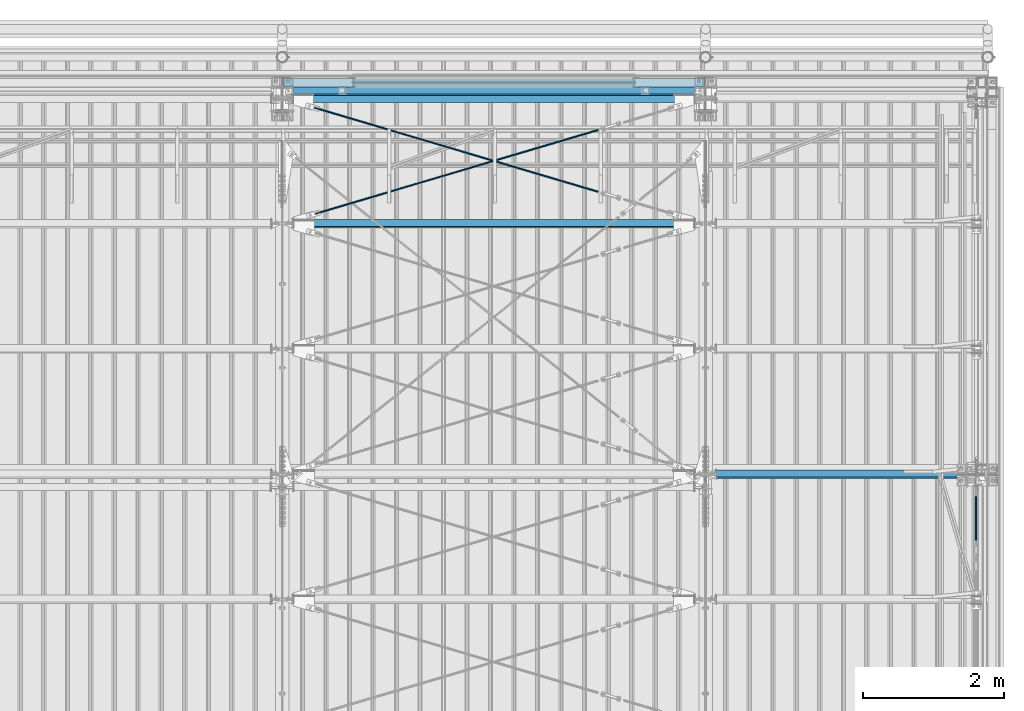
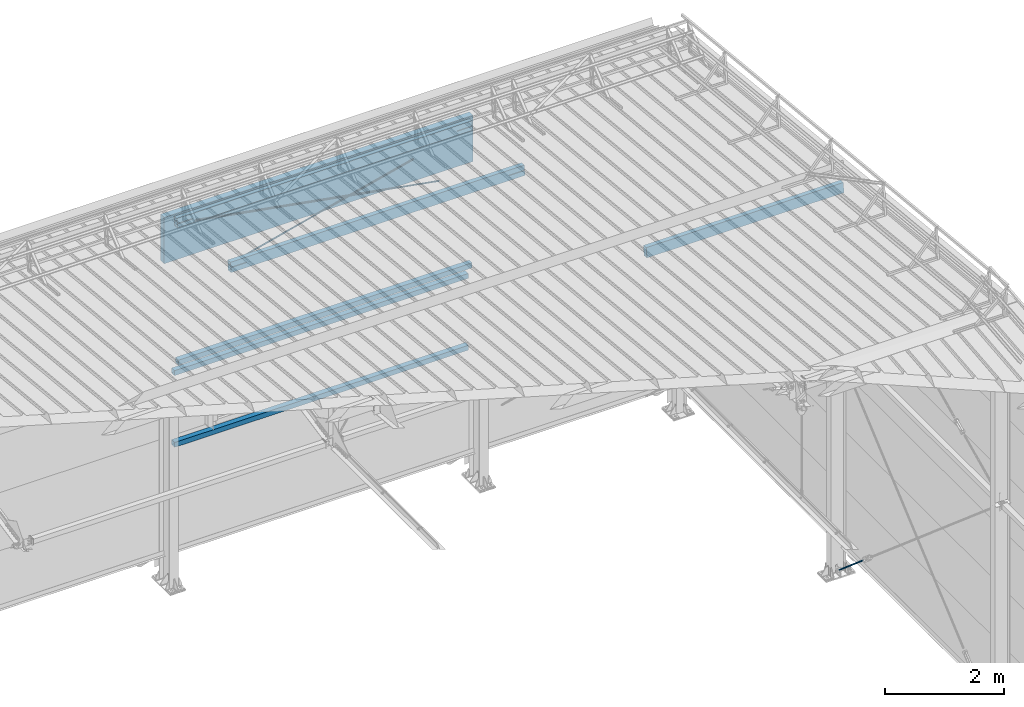
# One storey, part 288 of 709: 9 beams, 1 member, 7 openings, 10 elements without a shape of their own.
"""IFC4 building model written with IfcOpenShell, lengths in millimetres."""

from ifc_helpers import new_model, si_unit, direction, frame, origin_with_axes, place, context, subcontext, project, spatial, line, indexed_curve, outline, extrude, polygons, material, element, aggregate, save


model = new_model("IFC4")

# Units and contexts
model_context = context("Model", 3, precision=0.2, world=origin_with_axes(), true_north=direction((0.0, 1.0)))
body_context = subcontext(model_context, "Body", "Model", "MODEL_VIEW")
reference_context = subcontext(model_context, "Reference", "Model", "MODEL_VIEW")
ifc_project = project(units=[si_unit("LENGTHUNIT", "METRE", prefix="MILLI"), si_unit("AREAUNIT", "SQUARE_METRE"), si_unit("VOLUMEUNIT", "CUBIC_METRE"), si_unit("MASSUNIT", "GRAM", prefix="KILO"), si_unit("TIMEUNIT", "SECOND"), si_unit("PLANEANGLEUNIT", "RADIAN"), si_unit("SOLIDANGLEUNIT", "STERADIAN"), si_unit("THERMODYNAMICTEMPERATUREUNIT", "DEGREE_CELSIUS"), si_unit("LUMINOUSINTENSITYUNIT", "LUMEN")], contexts=[model_context])

# Site, building, storey
site_placement = place(None, origin_with_axes())
site = spatial("IfcSite", under=ifc_project, at=site_placement, CompositionType="ELEMENT")
building_placement = place(site_placement, origin_with_axes())
building = spatial("IfcBuilding", under=site, at=building_placement, Name="Undefined", CompositionType="ELEMENT")
storey_placement = place(building_placement, origin_with_axes())
storey = spatial("IfcBuildingStorey", under=building, at=storey_placement, Name="Undefined", CompositionType="ELEMENT", Elevation=0.0)

# Assembly, member, voiding feature
assembly_1_placement = place(storey_placement, frame((49835.0, 15435.54649, 754.36172), z_axis=(1.0, 0.0, 0.0), x_axis=(0.0, 0.7603239329, -0.649544084)))
assembly_1 = element("IfcElementAssembly", 1, at=assembly_1_placement, inside=storey)
ifc_material_1 = material(Name="C355-5", Category="STEEL")
member_placement = place(assembly_1_placement, origin_with_axes())
member = element("IfcMember", 2, at=member_placement, material=ifc_material_1, ObjectType="513", context=body_context, shape_type="Tessellation", body=[
    polygons([(1220.17807, -5.0, 8.66025), (1220.17807, -7.07107, 7.07107), (1220.17807, -8.66025, 5.0), (1220.17807, -9.65926, 2.58819), (1220.17807, -10.0, 0.0), (1220.17807, -9.65926, -2.58819), (1220.17807, -8.66025, -5.0), (1220.17807, -7.07107, -7.07107), (1220.17807, -5.0, -8.66025), (1220.17807, -2.58819, -9.65926), (1220.17807, 0.0, -10.0), (1220.17807, 2.58819, -9.65926), (1220.17807, 5.0, -8.66025), (1220.17807, 7.07107, -7.07107), (1220.17807, 8.66025, -5.0), (1220.17807, 9.65926, -2.58819), (1220.17807, 10.0, 0.0), (1220.17807, 9.65926, 2.58819), (1220.17807, 8.66025, 5.0), (1220.17807, 7.07107, 7.07107), (1220.17807, 5.0, 8.66025), (1220.17807, 2.58819, 9.65926), (1220.17807, 0.0, 10.0), (1220.17807, -2.58819, 9.65926), (190.0, 10.0, 0.0), (190.0, 9.65926, 2.58819), (190.0, 8.66025, 5.0), (190.0, 7.07107, 7.07107), (190.0, 5.0, 8.66025), (190.0, 2.58819, 9.65926), (190.0, 0.0, 10.0), (190.0, -2.58819, 9.65926), (190.0, -5.0, 8.66025), (190.0, -7.07107, 7.07107), (190.0, -8.66025, 5.0), (190.0, -9.65926, 2.58819), (190.0, -10.0, 0.0), (190.0, -9.65926, -2.58819), (190.0, -8.66025, -5.0), (190.0, -7.07107, -7.07107), (190.0, -5.0, -8.66025), (190.0, -2.58819, -9.65926), (190.0, 0.0, -10.0), (190.0, 2.58819, -9.65926), (190.0, 5.0, -8.66025), (190.0, 7.07107, -7.07107), (190.0, 8.66025, -5.0), (190.0, 9.65926, -2.58819), (10.0, 7.36122, 4.25), (190.0, 7.36122, 4.25), (190.0, 8.21037, 2.19996), (10.0, 8.21037, 2.19996), (10.0, 6.01041, 6.01041), (190.0, 6.01041, 6.01041), (10.0, 4.25, 7.36122), (190.0, 4.25, 7.36122), (10.0, 2.19996, 8.21037), (190.0, 2.19996, 8.21037), (10.0, 0.0, 8.5), (190.0, 0.0, 8.5), (10.0, -2.19996, 8.21037), (190.0, -2.19996, 8.21037), (10.0, -4.25, 7.36122), (190.0, -4.25, 7.36122), (10.0, -6.01041, 6.01041), (190.0, -6.01041, 6.01041), (10.0, -7.36122, 4.25), (190.0, -7.36122, 4.25), (10.0, -8.21037, 2.19996), (190.0, -8.21037, 2.19996), (10.0, -8.5, 0.0), (190.0, -8.5, 0.0), (10.0, -8.21037, -2.19996), (190.0, -8.21037, -2.19996), (10.0, -7.36122, -4.25), (190.0, -7.36122, -4.25), (10.0, -6.01041, -6.01041), (190.0, -6.01041, -6.01041), (10.0, -4.25, -7.36122), (190.0, -4.25, -7.36122), (10.0, -2.19996, -8.21037), (190.0, -2.19996, -8.21037), (10.0, 0.0, -8.5), (190.0, 0.0, -8.5), (10.0, 2.19996, -8.21037), (190.0, 2.19996, -8.21037), (10.0, 4.25, -7.36122), (190.0, 4.25, -7.36122), (10.0, 6.01041, -6.01041), (190.0, 6.01041, -6.01041), (10.0, 7.36122, -4.25), (190.0, 7.36122, -4.25), (10.0, 8.21037, -2.19996), (190.0, 8.21037, -2.19996), (10.0, 8.5, 0.0), (190.0, 8.5, 0.0)], [[[1, 2, 3, 4, 5, 6, 7, 8, 9, 10, 11, 12, 13, 14, 15, 16, 17, 18, 19, 20, 21, 22, 23, 24]], [[18, 17, 25, 26]], [[19, 18, 26, 27]], [[20, 19, 27, 28]], [[21, 20, 28, 29]], [[22, 21, 29, 30]], [[23, 22, 30, 31]], [[24, 23, 31, 32]], [[1, 24, 32, 33]], [[2, 1, 33, 34]], [[3, 2, 34, 35]], [[4, 3, 35, 36]], [[5, 4, 36, 37]], [[6, 5, 37, 38]], [[7, 6, 38, 39]], [[8, 7, 39, 40]], [[9, 8, 40, 41]], [[10, 9, 41, 42]], [[11, 10, 42, 43]], [[12, 11, 43, 44]], [[13, 12, 44, 45]], [[14, 13, 45, 46]], [[15, 14, 46, 47]], [[16, 15, 47, 48]], [[17, 16, 48, 25]], [[25, 48, 47, 46, 45, 44, 43, 42, 41, 40, 39, 38, 37, 36, 35, 34, 33, 32, 31, 30, 29, 28, 27, 26], [74, 76, 78, 80, 82, 84, 86, 88, 90, 92, 94, 96, 51, 50, 54, 56, 58, 60, 62, 64, 66, 68, 70, 72]], [[49, 50, 51, 52]], [[53, 54, 50, 49]], [[55, 56, 54, 53]], [[57, 58, 56, 55]], [[59, 60, 58, 57]], [[61, 62, 60, 59]], [[63, 64, 62, 61]], [[65, 66, 64, 63]], [[67, 68, 66, 65]], [[69, 70, 68, 67]], [[71, 72, 70, 69]], [[73, 74, 72, 71]], [[75, 76, 74, 73]], [[77, 78, 76, 75]], [[79, 80, 78, 77]], [[81, 82, 80, 79]], [[83, 84, 82, 81]], [[85, 86, 84, 83]], [[87, 88, 86, 85]], [[89, 90, 88, 87]], [[91, 92, 90, 89]], [[93, 94, 92, 91]], [[95, 96, 94, 93]], [[52, 51, 96, 95]], [[91, 89, 87, 85, 83, 81, 79, 77, 75, 73, 71, 69, 67, 65, 63, 61, 59, 57, 55, 53, 49, 52, 95, 93]]], closed=True),
])
voiding_feature_1_placement = place(member_placement, frame((10.0, 0.0, 0.0), z_axis=(0.0, -1.0, 0.0), x_axis=(1.0, 0.0, 0.0)))
element("IfcVoidingFeature", 3, at=voiding_feature_1_placement, cuts=member, PredefinedType="HOLE", context=reference_context, identifier="Reference", shape_type="SolidModel", body=[
    extrude(outline(indexed_curve([(10.5, 0.0), (10.14222, 2.7176), (9.09327, 5.25), (7.42462, 7.42462), (5.25, 9.09327), (2.7176, 10.14222), (0.0, 10.5), (-2.7176, 10.14222), (-5.25, 9.09327), (-7.42462, 7.42462), (-9.09327, 5.25), (-10.14222, 2.7176), (-10.5, 0.0), (-10.14222, -2.7176), (-9.09327, -5.25), (-7.42462, -7.42462), (-5.25, -9.09327), (-2.7176, -10.14222), (0.0, -10.5), (2.7176, -10.14222), (5.25, -9.09327), (7.42462, -7.42462), (9.09327, -5.25), (10.14222, -2.7176)], segments=[line(1, 2, 3, 4, 5, 6, 7, 8, 9, 10, 11, 12, 13, 14, 15, 16, 17, 18, 19, 20, 21, 22, 23, 24, 1)])), frame((0.0, 0.0, 0.0), z_axis=(-1.0, 0.0, 0.0), x_axis=(0.0, 0.0, 1.0)), (0.0, 0.0, -1.0), 180.0),
])
aggregate(assembly_1, [member])

# Assembly, beam
assembly_2_placement = place(storey_placement, frame((46000.0, 21950.0, 2550.0), z_axis=(0.0, 0.0, -1.0), x_axis=(-1.0, 0.0, 0.0)))
assembly_2 = element("IfcElementAssembly", 4, at=assembly_2_placement, inside=storey)
ifc_material_2 = material(Name="C355", Category="STEEL")
beam_1_placement = place(assembly_2_placement, origin_with_axes())
beam_1 = element("IfcBeam", 5, at=beam_1_placement, material=ifc_material_2, ObjectType="545", context=body_context, shape_type="Tessellation", body=[
    polygons([(155.0, -47.0, -47.0), (155.0, -47.0, 47.0), (5845.0, -47.0, 47.0), (5845.0, -47.0, -47.0), (155.0, 47.0, 47.0), (5845.0, 47.0, 47.0), (155.0, 47.0, -47.0), (5845.0, 47.0, -47.0), (155.0, -50.0, -50.0), (155.0, 50.0, -50.0), (5845.0, 50.0, -50.0), (5845.0, -50.0, -50.0), (155.0, 50.0, 50.0), (5845.0, 50.0, 50.0), (155.0, -50.0, 50.0), (5845.0, -50.0, 50.0)], [[[1, 2, 3, 4]], [[2, 5, 6, 3]], [[5, 7, 8, 6]], [[7, 1, 4, 8]], [[9, 10, 11, 12]], [[10, 13, 14, 11]], [[13, 15, 16, 14]], [[15, 9, 12, 16]], [[14, 16, 12, 11], [6, 8, 4, 3]], [[15, 13, 10, 9], [7, 5, 2, 1]]], closed=True),
])
aggregate(assembly_2, [beam_1])

assembly_3_placement = place(storey_placement, frame((46000.0, 21950.0, 4020.0), z_axis=(0.0, 0.0, -1.0), x_axis=(-1.0, 0.0, 0.0)))
assembly_3 = element("IfcElementAssembly", 6, at=assembly_3_placement, inside=storey)
beam_2_placement = place(assembly_3_placement, origin_with_axes())
beam_2 = element("IfcBeam", 7, at=beam_2_placement, material=ifc_material_2, ObjectType="545", context=body_context, shape_type="Tessellation", body=[
    polygons([(155.0, -47.0, -47.0), (155.0, -47.0, 47.0), (5845.0, -47.0, 47.0), (5845.0, -47.0, -47.0), (155.0, 47.0, 47.0), (5845.0, 47.0, 47.0), (155.0, 47.0, -47.0), (5845.0, 47.0, -47.0), (155.0, -50.0, -50.0), (155.0, 50.0, -50.0), (5845.0, 50.0, -50.0), (5845.0, -50.0, -50.0), (155.0, 50.0, 50.0), (5845.0, 50.0, 50.0), (155.0, -50.0, 50.0), (5845.0, -50.0, 50.0)], [[[1, 2, 3, 4]], [[2, 5, 6, 3]], [[5, 7, 8, 6]], [[7, 1, 4, 8]], [[9, 10, 11, 12]], [[10, 13, 14, 11]], [[13, 15, 16, 14]], [[15, 9, 12, 16]], [[14, 16, 12, 11], [6, 8, 4, 3]], [[15, 13, 10, 9], [7, 5, 2, 1]]], closed=True),
])
aggregate(assembly_3, [beam_2])

assembly_4_placement = place(storey_placement, frame((46000.0, 21827.0, 4310.0), z_axis=(0.0, 0.0, -1.0), x_axis=(-1.0, 0.0, 0.0)))
assembly_4 = element("IfcElementAssembly", 8, at=assembly_4_placement, inside=storey)
beam_3_placement = place(assembly_4_placement, origin_with_axes())
beam_3 = element("IfcBeam", 9, at=beam_3_placement, material=ifc_material_2, ObjectType="546", context=body_context, shape_type="Tessellation", body=[
    polygons([(155.0, -47.0, -47.0), (155.0, -47.0, 47.0), (5845.0, -47.0, 47.0), (5845.0, -47.0, -47.0), (155.0, 47.0, 47.0), (5845.0, 47.0, 47.0), (155.0, 47.0, -47.0), (5845.0, 47.0, -47.0), (155.0, -50.0, -50.0), (155.0, 50.0, -50.0), (5845.0, 50.0, -50.0), (5845.0, -50.0, -50.0), (155.0, 50.0, 50.0), (5845.0, 50.0, 50.0), (155.0, -50.0, 50.0), (5845.0, -50.0, 50.0)], [[[1, 2, 3, 4]], [[2, 5, 6, 3]], [[5, 7, 8, 6]], [[7, 1, 4, 8]], [[9, 10, 11, 12]], [[10, 13, 14, 11]], [[13, 15, 16, 14]], [[15, 9, 12, 16]], [[14, 16, 12, 11], [6, 8, 4, 3]], [[15, 13, 10, 9], [7, 5, 2, 1]]], closed=True),
])
aggregate(assembly_4, [beam_3])

# Assembly, beam, voiding feature
assembly_5_placement = place(storey_placement, frame((40000.0, 20064.14591, 7330.08943), z_axis=(0.2852311229, -0.9537021177, 0.0953702118), x_axis=(0.9584587662, 0.2838155751, -0.028381558)))
assembly_5 = element("IfcElementAssembly", 10, at=assembly_5_placement, inside=storey)
beam_4_placement = place(assembly_5_placement, origin_with_axes())
beam_4 = element("IfcBeam", 11, at=beam_4_placement, material=ifc_material_1, ObjectType="570", context=body_context, shape_type="Tessellation", body=[
    polygons([(4850.05021, 7.36122, 4.25), (4850.05021, 6.01041, 6.01041), (4850.05021, 4.25, 7.36121), (4850.05021, 2.19996, 8.21037), (4850.05021, 0.0, 8.5), (4850.05021, -2.19996, 8.21037), (4850.05021, -4.25, 7.36121), (4850.05021, -6.01041, 6.01041), (4850.05021, -7.36121, 4.25), (4850.05021, -8.21037, 2.19996), (4850.05021, -8.5, 0.0), (4850.05021, -8.21037, -2.19996), (4850.05021, -7.36121, -4.25), (4850.05021, -6.01041, -6.01041), (4850.05021, -4.25, -7.36122), (4850.05021, -2.19996, -8.21037), (4850.05021, 0.0, -8.5), (4850.05021, 2.19996, -8.21037), (4850.05021, 4.25, -7.36122), (4850.05021, 6.01041, -6.01041), (4850.05021, 7.36122, -4.25), (4850.05021, 8.21037, -2.19996), (4850.05021, 8.5, 0.0), (4850.05021, 8.21037, 2.19996), (4670.05021, 8.21037, 2.19996), (4670.05021, 7.36122, 4.25), (4670.05021, 6.01041, 6.01041), (4670.05021, 4.25, 7.36121), (4670.05021, 2.19996, 8.21037), (4670.05021, 0.0, 8.5), (4670.05021, -2.19996, 8.21037), (4670.05021, -4.25, 7.36121), (4670.05021, -6.01041, 6.01041), (4670.05021, -7.36121, 4.25), (4670.05021, -8.21037, 2.19996), (4670.05021, -8.5, 0.0), (4670.05021, -8.21037, -2.19996), (4670.05021, -7.36121, -4.25), (4670.05021, -6.01041, -6.01041), (4670.05021, -4.25, -7.36122), (4670.05021, -2.19996, -8.21037), (4670.05021, 0.0, -8.5), (4670.05021, 2.19996, -8.21037), (4670.05021, 4.25, -7.36122), (4670.05021, 6.01041, -6.01041), (4670.05021, 7.36122, -4.25), (4670.05021, 8.21037, -2.19996), (4670.05021, 8.5, 0.0), (4670.05021, 10.0, 0.0), (4670.05021, 9.65926, 2.58819), (4670.05021, 8.66025, 5.0), (4670.05021, 7.07107, 7.07107), (4670.05021, 5.0, 8.66025), (4670.05021, 2.58819, 9.65926), (4670.05021, 0.0, 10.0), (4670.05021, -2.58819, 9.65926), (4670.05021, -5.0, 8.66025), (4670.05021, -7.07107, 7.07107), (4670.05021, -8.66025, 5.0), (4670.05021, -9.65926, 2.58819), (4670.05021, -10.0, 0.0), (4670.05021, -9.65926, -2.58819), (4670.05021, -8.66025, -5.0), (4670.05021, -7.07107, -7.07107), (4670.05021, -5.0, -8.66025), (4670.05021, -2.58819, -9.65926), (4670.05021, 0.0, -10.0), (4670.05021, 2.58819, -9.65926), (4670.05021, 5.0, -8.66025), (4670.05021, 7.07107, -7.07107), (4670.05021, 8.66025, -5.0), (4670.05021, 9.65926, -2.58819), (483.0251, 2.58819, 9.65926), (483.0251, 5.0, 8.66025), (483.0251, 7.07107, 7.07107), (483.0251, 8.66025, 5.0), (483.0251, 9.65926, 2.58819), (483.0251, 10.0, 0.0), (483.0251, 9.65926, -2.58819), (483.0251, 8.66025, -5.0), (483.0251, 7.07107, -7.07107), (483.0251, 5.0, -8.66025), (483.0251, 2.58819, -9.65926), (483.0251, 0.0, -10.0), (483.0251, -2.58819, -9.65926), (483.0251, -5.0, -8.66025), (483.0251, -7.07107, -7.07107), (483.0251, -8.66025, -5.0), (483.0251, -9.65926, -2.58819), (483.0251, -10.0, 0.0), (483.0251, -9.65926, 2.58819), (483.0251, -8.66025, 5.0), (483.0251, -7.07107, 7.07107), (483.0251, -5.0, 8.66025), (483.0251, -2.58819, 9.65926), (483.0251, 0.0, 10.0)], [[[1, 2, 3, 4, 5, 6, 7, 8, 9, 10, 11, 12, 13, 14, 15, 16, 17, 18, 19, 20, 21, 22, 23, 24]], [[24, 25, 26, 1]], [[1, 26, 27, 2]], [[2, 27, 28, 3]], [[3, 28, 29, 4]], [[4, 29, 30, 5]], [[5, 30, 31, 6]], [[6, 31, 32, 7]], [[7, 32, 33, 8]], [[8, 33, 34, 9]], [[9, 34, 35, 10]], [[10, 35, 36, 11]], [[11, 36, 37, 12]], [[12, 37, 38, 13]], [[13, 38, 39, 14]], [[14, 39, 40, 15]], [[15, 40, 41, 16]], [[16, 41, 42, 17]], [[17, 42, 43, 18]], [[18, 43, 44, 19]], [[19, 44, 45, 20]], [[20, 45, 46, 21]], [[21, 46, 47, 22]], [[22, 47, 48, 23]], [[23, 48, 25, 24]], [[49, 50, 51, 52, 53, 54, 55, 56, 57, 58, 59, 60, 61, 62, 63, 64, 65, 66, 67, 68, 69, 70, 71, 72], [47, 46, 45, 44, 43, 42, 41, 40, 39, 38, 37, 36, 35, 34, 33, 32, 31, 30, 29, 28, 27, 26, 25, 48]], [[73, 74, 75, 76, 77, 78, 79, 80, 81, 82, 83, 84, 85, 86, 87, 88, 89, 90, 91, 92, 93, 94, 95, 96]], [[79, 78, 49, 72]], [[80, 79, 72, 71]], [[81, 80, 71, 70]], [[82, 81, 70, 69]], [[83, 82, 69, 68]], [[84, 83, 68, 67]], [[85, 84, 67, 66]], [[86, 85, 66, 65]], [[87, 86, 65, 64]], [[88, 87, 64, 63]], [[89, 88, 63, 62]], [[90, 89, 62, 61]], [[91, 90, 61, 60]], [[92, 91, 60, 59]], [[93, 92, 59, 58]], [[94, 93, 58, 57]], [[95, 94, 57, 56]], [[96, 95, 56, 55]], [[73, 96, 55, 54]], [[74, 73, 54, 53]], [[75, 74, 53, 52]], [[76, 75, 52, 51]], [[77, 76, 51, 50]], [[78, 77, 50, 49]]], closed=True),
])
voiding_feature_2_placement = place(beam_4_placement, frame((4850.05021, 0.0, 0.0), z_axis=(0.0, 1.0, 0.0), x_axis=(-1.0, 0.0, 0.0)))
element("IfcVoidingFeature", 12, at=voiding_feature_2_placement, cuts=beam_4, PredefinedType="HOLE", context=reference_context, identifier="Reference", shape_type="SolidModel", body=[
    extrude(outline(indexed_curve([(10.5, 0.0), (10.14222, 2.7176), (9.09327, 5.25), (7.42462, 7.42462), (5.25, 9.09327), (2.7176, 10.14222), (0.0, 10.5), (-2.7176, 10.14222), (-5.25, 9.09327), (-7.42462, 7.42462), (-9.09327, 5.25), (-10.14222, 2.7176), (-10.5, 0.0), (-10.14222, -2.7176), (-9.09327, -5.25), (-7.42462, -7.42462), (-5.25, -9.09327), (-2.7176, -10.14222), (0.0, -10.5), (2.7176, -10.14222), (5.25, -9.09327), (7.42462, -7.42462), (9.09327, -5.25), (10.14222, -2.7176)], segments=[line(1, 2, 3, 4, 5, 6, 7, 8, 9, 10, 11, 12, 13, 14, 15, 16, 17, 18, 19, 20, 21, 22, 23, 24, 1)])), frame((0.0, 0.0, 0.0), z_axis=(-1.0, 0.0, 0.0), x_axis=(0.0, 0.0, 1.0)), (0.0, 0.0, -1.0), 180.0),
])
aggregate(assembly_5, [beam_4])

assembly_6_placement = place(storey_placement, frame((40000.0, 21840.84566, 7152.41945), z_axis=(-0.2852311229, -0.9537021177, 0.0953702118), x_axis=(0.9584587662, -0.2838155751, 0.028381558)))
assembly_6 = element("IfcElementAssembly", 13, at=assembly_6_placement, inside=storey)
beam_5_placement = place(assembly_6_placement, origin_with_axes())
beam_5 = element("IfcBeam", 14, at=beam_5_placement, material=ifc_material_1, ObjectType="568", context=body_context, shape_type="Tessellation", body=[
    polygons([(4850.05021, 7.36121, 4.25), (4850.05021, 6.01041, 6.01041), (4850.05021, 4.25, 7.36122), (4850.05021, 2.19996, 8.21037), (4850.05021, 0.0, 8.5), (4850.05021, -2.19996, 8.21037), (4850.05021, -4.25, 7.36122), (4850.05021, -6.01041, 6.01041), (4850.05021, -7.36122, 4.25), (4850.05021, -8.21037, 2.19996), (4850.05021, -8.5, 0.0), (4850.05021, -8.21037, -2.19996), (4850.05021, -7.36122, -4.25), (4850.05021, -6.01041, -6.01041), (4850.05021, -4.25, -7.36121), (4850.05021, -2.19996, -8.21037), (4850.05021, 0.0, -8.5), (4850.05021, 2.19996, -8.21037), (4850.05021, 4.25, -7.36121), (4850.05021, 6.01041, -6.01041), (4850.05021, 7.36121, -4.25), (4850.05021, 8.21037, -2.19996), (4850.05021, 8.5, 0.0), (4850.05021, 8.21037, 2.19996), (4670.05021, 8.21037, 2.19996), (4670.05021, 7.36121, 4.25), (4670.05021, 6.01041, 6.01041), (4670.05021, 4.25, 7.36122), (4670.05021, 2.19996, 8.21037), (4670.05021, 0.0, 8.5), (4670.05021, -2.19996, 8.21037), (4670.05021, -4.25, 7.36122), (4670.05021, -6.01041, 6.01041), (4670.05021, -7.36122, 4.25), (4670.05021, -8.21037, 2.19996), (4670.05021, -8.5, 0.0), (4670.05021, -8.21037, -2.19996), (4670.05021, -7.36122, -4.25), (4670.05021, -6.01041, -6.01041), (4670.05021, -4.25, -7.36121), (4670.05021, -2.19996, -8.21037), (4670.05021, 0.0, -8.5), (4670.05021, 2.19996, -8.21037), (4670.05021, 4.25, -7.36121), (4670.05021, 6.01041, -6.01041), (4670.05021, 7.36121, -4.25), (4670.05021, 8.21037, -2.19996), (4670.05021, 8.5, 0.0), (4670.05021, 10.0, 0.0), (4670.05021, 9.65926, 2.58819), (4670.05021, 8.66025, 5.0), (4670.05021, 7.07107, 7.07107), (4670.05021, 5.0, 8.66025), (4670.05021, 2.58819, 9.65926), (4670.05021, 0.0, 10.0), (4670.05021, -2.58819, 9.65926), (4670.05021, -5.0, 8.66025), (4670.05021, -7.07107, 7.07107), (4670.05021, -8.66025, 5.0), (4670.05021, -9.65926, 2.58819), (4670.05021, -10.0, 0.0), (4670.05021, -9.65926, -2.58819), (4670.05021, -8.66025, -5.0), (4670.05021, -7.07107, -7.07107), (4670.05021, -5.0, -8.66025), (4670.05021, -2.58819, -9.65926), (4670.05021, 0.0, -10.0), (4670.05021, 2.58819, -9.65926), (4670.05021, 5.0, -8.66025), (4670.05021, 7.07107, -7.07107), (4670.05021, 8.66025, -5.0), (4670.05021, 9.65926, -2.58819), (468.0251, 2.58819, 9.65926), (468.0251, 5.0, 8.66025), (468.0251, 7.07107, 7.07107), (468.0251, 8.66025, 5.0), (468.0251, 9.65926, 2.58819), (468.0251, 10.0, 0.0), (468.0251, 9.65926, -2.58819), (468.0251, 8.66025, -5.0), (468.0251, 7.07107, -7.07107), (468.0251, 5.0, -8.66025), (468.0251, 2.58819, -9.65926), (468.0251, 0.0, -10.0), (468.0251, -2.58819, -9.65926), (468.0251, -5.0, -8.66025), (468.0251, -7.07107, -7.07107), (468.0251, -8.66025, -5.0), (468.0251, -9.65926, -2.58819), (468.0251, -10.0, 0.0), (468.0251, -9.65926, 2.58819), (468.0251, -8.66025, 5.0), (468.0251, -7.07107, 7.07107), (468.0251, -5.0, 8.66025), (468.0251, -2.58819, 9.65926), (468.0251, 0.0, 10.0)], [[[1, 2, 3, 4, 5, 6, 7, 8, 9, 10, 11, 12, 13, 14, 15, 16, 17, 18, 19, 20, 21, 22, 23, 24]], [[24, 25, 26, 1]], [[1, 26, 27, 2]], [[2, 27, 28, 3]], [[3, 28, 29, 4]], [[4, 29, 30, 5]], [[5, 30, 31, 6]], [[6, 31, 32, 7]], [[7, 32, 33, 8]], [[8, 33, 34, 9]], [[9, 34, 35, 10]], [[10, 35, 36, 11]], [[11, 36, 37, 12]], [[12, 37, 38, 13]], [[13, 38, 39, 14]], [[14, 39, 40, 15]], [[15, 40, 41, 16]], [[16, 41, 42, 17]], [[17, 42, 43, 18]], [[18, 43, 44, 19]], [[19, 44, 45, 20]], [[20, 45, 46, 21]], [[21, 46, 47, 22]], [[22, 47, 48, 23]], [[23, 48, 25, 24]], [[49, 50, 51, 52, 53, 54, 55, 56, 57, 58, 59, 60, 61, 62, 63, 64, 65, 66, 67, 68, 69, 70, 71, 72], [47, 46, 45, 44, 43, 42, 41, 40, 39, 38, 37, 36, 35, 34, 33, 32, 31, 30, 29, 28, 27, 26, 25, 48]], [[73, 74, 75, 76, 77, 78, 79, 80, 81, 82, 83, 84, 85, 86, 87, 88, 89, 90, 91, 92, 93, 94, 95, 96]], [[79, 78, 49, 72]], [[80, 79, 72, 71]], [[81, 80, 71, 70]], [[82, 81, 70, 69]], [[83, 82, 69, 68]], [[84, 83, 68, 67]], [[85, 84, 67, 66]], [[86, 85, 66, 65]], [[87, 86, 65, 64]], [[88, 87, 64, 63]], [[89, 88, 63, 62]], [[90, 89, 62, 61]], [[91, 90, 61, 60]], [[92, 91, 60, 59]], [[93, 92, 59, 58]], [[94, 93, 58, 57]], [[95, 94, 57, 56]], [[96, 95, 56, 55]], [[73, 96, 55, 54]], [[74, 73, 54, 53]], [[75, 74, 53, 52]], [[76, 75, 52, 51]], [[77, 76, 51, 50]], [[78, 77, 50, 49]]], closed=True),
])
voiding_feature_3_placement = place(beam_5_placement, frame((4850.05021, 0.0, 0.0), z_axis=(0.0, 1.0, 0.0), x_axis=(-1.0, 0.0, 0.0)))
element("IfcVoidingFeature", 15, at=voiding_feature_3_placement, cuts=beam_5, PredefinedType="HOLE", context=reference_context, identifier="Reference", shape_type="SolidModel", body=[
    extrude(outline(indexed_curve([(10.5, 0.0), (10.14222, 2.7176), (9.09327, 5.25), (7.42462, 7.42462), (5.25, 9.09327), (2.7176, 10.14222), (0.0, 10.5), (-2.7176, 10.14222), (-5.25, 9.09327), (-7.42462, 7.42462), (-9.09327, 5.25), (-10.14222, 2.7176), (-10.5, 0.0), (-10.14222, -2.7176), (-9.09327, -5.25), (-7.42462, -7.42462), (-5.25, -9.09327), (-2.7176, -10.14222), (0.0, -10.5), (2.7176, -10.14222), (5.25, -9.09327), (7.42462, -7.42462), (9.09327, -5.25), (10.14222, -2.7176)], segments=[line(1, 2, 3, 4, 5, 6, 7, 8, 9, 10, 11, 12, 13, 14, 15, 16, 17, 18, 19, 20, 21, 22, 23, 24, 1)])), frame((0.0, 0.0, 0.0), z_axis=(-1.0, 0.0, 0.0), x_axis=(0.0, 0.0, 1.0)), (0.0, 0.0, -1.0), 180.0),
])
aggregate(assembly_6, [beam_5])

# Assembly, beam
assembly_7_placement = place(storey_placement, frame((50000.0, 16509.95037, 7677.46908), z_axis=(0.0, -0.9950371902, 0.099503719), x_axis=(-1.0, 0.0, 0.0)))
assembly_7 = element("IfcElementAssembly", 16, at=assembly_7_placement, inside=storey)
beam_6_placement = place(assembly_7_placement, origin_with_axes())
beam_6 = element("IfcBeam", 17, at=beam_6_placement, material=ifc_material_2, ObjectType="564", context=body_context, shape_type="Tessellation", body=[
    polygons([(3845.0, 100.0, 50.0), (3845.0, 100.0, -50.0), (28.0, 100.0, -50.0), (28.0, 100.0, 50.0), (3845.0, -100.0, 50.0), (28.0, -100.0, 50.0), (3845.0, -100.0, -50.0), (28.0, -100.0, -50.0), (3845.0, 96.0, -46.0), (3845.0, 96.0, 46.0), (28.0, 96.0, 46.0), (28.0, 96.0, -46.0), (3845.0, -96.0, -46.0), (28.0, -96.0, -46.0), (3845.0, -96.0, 46.0), (28.0, -96.0, 46.0)], [[[1, 2, 3, 4]], [[5, 1, 4, 6]], [[7, 5, 6, 8]], [[2, 7, 8, 3]], [[1, 5, 7, 2], [10, 9, 13, 15]], [[9, 10, 11, 12]], [[13, 9, 12, 14]], [[15, 13, 14, 16]], [[10, 15, 16, 11]], [[8, 6, 4, 3], [14, 12, 11, 16]]], closed=True),
])
aggregate(assembly_7, [beam_6])

# Assembly, beam, voiding features
assembly_8_placement = place(storey_placement, frame((46000.0, 20063.34988, 7322.12913), z_axis=(0.0, -0.9950371902, 0.099503719), x_axis=(-1.0, 0.0, 0.0)))
assembly_8 = element("IfcElementAssembly", 18, at=assembly_8_placement, inside=storey)
beam_7_placement = place(assembly_8_placement, origin_with_axes())
beam_7 = element("IfcBeam", 19, at=beam_7_placement, material=ifc_material_2, ObjectType="566", context=body_context, shape_type="Tessellation", body=[
    polygons([(456.62586, -5.0, 50.0), (456.62586, -5.0, 46.0), (155.0, -5.0, 46.0), (155.0, -5.0, 50.0), (456.62586, 5.0, 50.0), (456.62586, 5.0, 46.0), (155.0, 5.0, 50.0), (155.0, 5.0, 46.0), (456.62586, -5.0, -46.0), (456.62586, -5.0, -50.0), (155.0, -5.0, -50.0), (155.0, -5.0, -46.0), (456.62586, 5.0, -46.0), (456.62586, 5.0, -50.0), (155.0, 5.0, -46.0), (155.0, 5.0, -50.0), (155.0, 96.0, 46.0), (155.0, 96.0, -46.0), (5845.0, 96.0, -46.0), (5845.0, 96.0, 46.0), (155.0, 100.0, -50.0), (5845.0, 100.0, -50.0), (5845.0, 5.0, -50.0), (5543.37413, 5.0, -50.0), (5543.37413, -5.0, -50.0), (5845.0, -5.0, -50.0), (5845.0, -100.0, -50.0), (155.0, -100.0, -50.0), (5845.00055, 5.0, -46.0), (5543.37413, 5.0, -46.0), (5543.37413, -5.0, -46.0), (5845.0, -5.0, -46.0), (155.0, -96.0, -46.0), (155.0, -96.0, 46.0), (5845.0, -96.0, 46.0), (5845.0, -96.0, -46.0), (5543.37413, -5.0, 50.0), (5543.37413, -5.0, 46.0), (5543.37413, 5.0, 46.0), (5543.37413, 5.0, 50.0), (5845.0, -5.0, 50.0), (5845.0, -5.0, 46.0), (5845.0, -100.0, 50.0), (155.0, -100.0, 50.0), (5845.0, 5.0, 46.0), (5845.00055, 5.0, 50.0), (5845.0, 100.0, 50.0), (155.0, 100.0, 50.0)], [[[1, 2, 3, 4]], [[5, 6, 2, 1]], [[7, 8, 6, 5]], [[9, 10, 11, 12]], [[13, 14, 10, 9]], [[15, 16, 14, 13]], [[17, 18, 19, 20]], [[21, 22, 23, 24, 25, 26, 27, 28, 11, 10, 14, 16]], [[29, 30, 24, 23]], [[31, 25, 24, 30]], [[32, 26, 25, 31]], [[33, 34, 35, 36]], [[37, 38, 39, 40]], [[41, 42, 38, 37]], [[43, 27, 26, 32, 36, 35, 42, 41]], [[44, 28, 27, 43]], [[34, 33, 12, 11, 28, 44, 4, 3]], [[17, 20, 45, 39, 38, 42, 35, 34, 3, 2, 6, 8]], [[46, 40, 39, 45]], [[20, 19, 29, 23, 22, 47, 46, 45]], [[21, 48, 47, 22]], [[4, 44, 43, 41, 37, 40, 46, 47, 48, 7, 5, 1]], [[48, 21, 16, 15, 18, 17, 8, 7]], [[12, 33, 36, 32, 31, 30, 29, 19, 18, 15, 13, 9]]], closed=True),
])
voiding_feature_4_placement = place(beam_7_placement, frame((5845.00055, 0.0, -93.07721), z_axis=(0.0, -1.0, 0.0), x_axis=(0.0, 0.0, 1.0)))
element("IfcVoidingFeature", 20, at=voiding_feature_4_placement, cuts=beam_7, Name="PLATE", PredefinedType="HOLE", context=reference_context, identifier="Reference", shape_type="SolidModel", body=[
    extrude(outline(indexed_curve([(0.0, 0.0), (186.15442, 0.0), (268.27702, 275.95562), (182.01573, 301.62642), (4.13868, 301.62642), (-82.1226, 275.95562)], segments=[line(1, 2, 3, 4, 5, 6, 1)])), frame((0.0, 0.0, 5.0), z_axis=(0.0, 0.0, 1.0), x_axis=(1.0, 0.0, 0.0)), (0.0, 0.0, -1.0), 10.0),
])
voiding_feature_5_placement = place(beam_7_placement, frame((154.99945, 0.0, 93.07721), z_axis=(0.0, -1.0, 0.0), x_axis=(0.0, 0.0, -1.0)))
element("IfcVoidingFeature", 21, at=voiding_feature_5_placement, cuts=beam_7, Name="PLATE", PredefinedType="HOLE", context=reference_context, identifier="Reference", shape_type="SolidModel", body=[
    extrude(outline(indexed_curve([(0.0, 0.0), (186.15442, 0.0), (268.27702, 275.95562), (182.01573, 301.62642), (4.13868, 301.62642), (-82.1226, 275.95562)], segments=[line(1, 2, 3, 4, 5, 6, 1)])), frame((0.0, 0.0, 5.0), z_axis=(0.0, 0.0, 1.0), x_axis=(1.0, 0.0, 0.0)), (0.0, 0.0, -1.0), 10.0),
])
aggregate(assembly_8, [beam_7])

assembly_9_placement = place(storey_placement, frame((46000.0, 21841.04467, 7154.40952), z_axis=(0.0, -0.9950371902, 0.099503719), x_axis=(-1.0, 0.0, 0.0)))
assembly_9 = element("IfcElementAssembly", 22, at=assembly_9_placement, inside=storey)
beam_8_placement = place(assembly_9_placement, origin_with_axes())
beam_8 = element("IfcBeam", 23, at=beam_8_placement, material=ifc_material_2, ObjectType="565", context=body_context, shape_type="Tessellation", body=[
    polygons([(5855.0, 5.0, 50.0), (5855.0, 5.0, 46.0), (5557.75102, 5.0, 46.0), (5557.75102, 5.0, 50.0), (5557.75102, 15.0, 46.0), (5557.75102, 15.0, 50.0), (5855.0, 15.0, 50.0), (5855.0, 15.0, 46.0), (5855.0, 5.0, -46.0), (5855.0, 5.0, -50.0), (5557.75102, 5.0, -50.0), (5557.75102, 5.0, -46.0), (5557.75102, 15.0, -50.0), (5557.75102, 15.0, -46.0), (5855.0, 15.0, -46.0), (5855.0, 15.0, -50.0), (145.0, 86.0, 46.0), (145.0, 86.0, -46.0), (5855.0, 86.0, -46.0), (5855.0, 86.0, 46.0), (5855.0, -86.0, 46.0), (145.0, -86.0, 46.0), (145.0, 5.0, 46.0), (442.24898, 5.0, 46.0), (442.24898, 15.0, 46.0), (145.0, 15.0, 46.0), (145.0, -86.0, -46.0), (5855.0, -86.0, -46.0), (145.0, 15.0, -46.0), (145.0, 15.0, -50.0), (442.24898, 15.0, -50.0), (442.24898, 15.0, -46.0), (442.24898, 5.0, -50.0), (442.24898, 5.0, -46.0), (145.0, 5.0, -50.0), (145.0, 5.0, -46.0), (145.0, -90.0, -50.0), (145.0, -90.0, 50.0), (145.0, 5.0, 50.0), (442.24898, 5.0, 50.0), (442.24898, 15.0, 50.0), (145.0, 15.0, 50.0), (145.0, 90.0, 50.0), (145.0, 90.0, -50.0), (5855.0, 90.0, 50.0), (5855.0, 90.0, -50.0), (5855.0, -90.0, -50.0), (5855.0, -90.0, 50.0)], [[[1, 2, 3, 4]], [[4, 3, 5, 6]], [[7, 6, 5, 8]], [[9, 10, 11, 12]], [[12, 11, 13, 14]], [[15, 14, 13, 16]], [[17, 18, 19, 20]], [[3, 2, 21, 22, 23, 24, 25, 26, 17, 20, 8, 5]], [[27, 22, 21, 28]], [[29, 30, 31, 32]], [[32, 31, 33, 34]], [[34, 33, 35, 36]], [[22, 27, 36, 35, 37, 38, 39, 23]], [[40, 24, 23, 39]], [[41, 25, 24, 40]], [[42, 26, 25, 41]], [[43, 44, 30, 29, 18, 17, 26, 42]], [[44, 43, 45, 46]], [[20, 19, 15, 16, 46, 45, 7, 8]], [[11, 10, 47, 37, 35, 33, 31, 30, 44, 46, 16, 13]], [[38, 37, 47, 48]], [[45, 43, 42, 41, 40, 39, 38, 48, 1, 4, 6, 7]], [[48, 47, 10, 9, 28, 21, 2, 1]], [[19, 18, 29, 32, 34, 36, 27, 28, 9, 12, 14, 15]]], closed=True),
])
voiding_feature_6_placement = place(beam_8_placement, frame((145.0, 10.0, -70.0), z_axis=(0.0, -1.0, 0.0), x_axis=(1.0, 0.0, 0.0)))
element("IfcVoidingFeature", 24, at=voiding_feature_6_placement, cuts=beam_8, PredefinedType="HOLE", context=reference_context, identifier="Reference", shape_type="SolidModel", body=[
    extrude(outline(indexed_curve([(0.0, 0.0), (297.24898, 0.0), (297.24898, 154.66006), (271.57818, 240.92135), (0.0, 160.10144)], segments=[line(1, 2, 3, 4, 5, 1)])), frame((0.0, 0.0, 5.0), z_axis=(0.0, 0.0, 1.0), x_axis=(1.0, 0.0, 0.0)), (0.0, 0.0, -1.0), 10.0),
])
voiding_feature_7_placement = place(beam_8_placement, frame((5557.75102, 10.0, -70.0), z_axis=(0.0, -1.0, 0.0), x_axis=(1.0, 0.0, 0.0)))
element("IfcVoidingFeature", 25, at=voiding_feature_7_placement, cuts=beam_8, PredefinedType="HOLE", context=reference_context, identifier="Reference", shape_type="SolidModel", body=[
    extrude(outline(indexed_curve([(0.0, 0.0), (297.24898, 0.0), (297.24898, 160.10144), (25.6708, 240.92135), (0.0, 154.66006)], segments=[line(1, 2, 3, 4, 5, 1)])), frame((0.0, 0.0, 5.0), z_axis=(0.0, 0.0, 1.0), x_axis=(1.0, 0.0, 0.0)), (0.0, 0.0, -1.0), 10.0),
])
aggregate(assembly_9, [beam_8])

# Assembly, beam
assembly_10_placement = place(storey_placement, frame((40010.0, 22060.0, 6845.0), z_axis=(0.0, 0.0, -1.0), x_axis=(1.0, 0.0, 0.0)))
assembly_10 = element("IfcElementAssembly", 26, at=assembly_10_placement, inside=storey)
ifc_material_3 = material(Name="Insulation", Category="Insulation")
beam_9_placement = place(assembly_10_placement, origin_with_axes())
beam_9 = element("IfcBeam", 27, at=beam_9_placement, material=ifc_material_3, ObjectType="P-108", context=body_context, shape_type="Tessellation", body=[
    polygons([(0.0, 60.0, 595.0), (0.0, -60.0, 595.0), (5980.0, -60.0, 595.0), (5980.0, 60.0, 595.0), (5980.0, 60.0, -351.923), (0.0, 60.0, -351.923), (0.0, -60.0, -351.923), (5980.0, -60.0, -351.923)], [[[1, 2, 3, 4]], [[1, 4, 5, 6]], [[2, 1, 6, 7]], [[3, 2, 7, 8]], [[4, 3, 8, 5]], [[7, 6, 5, 8]]], closed=True),
])
aggregate(assembly_10, [beam_9])

save(model, "model.ifc")
